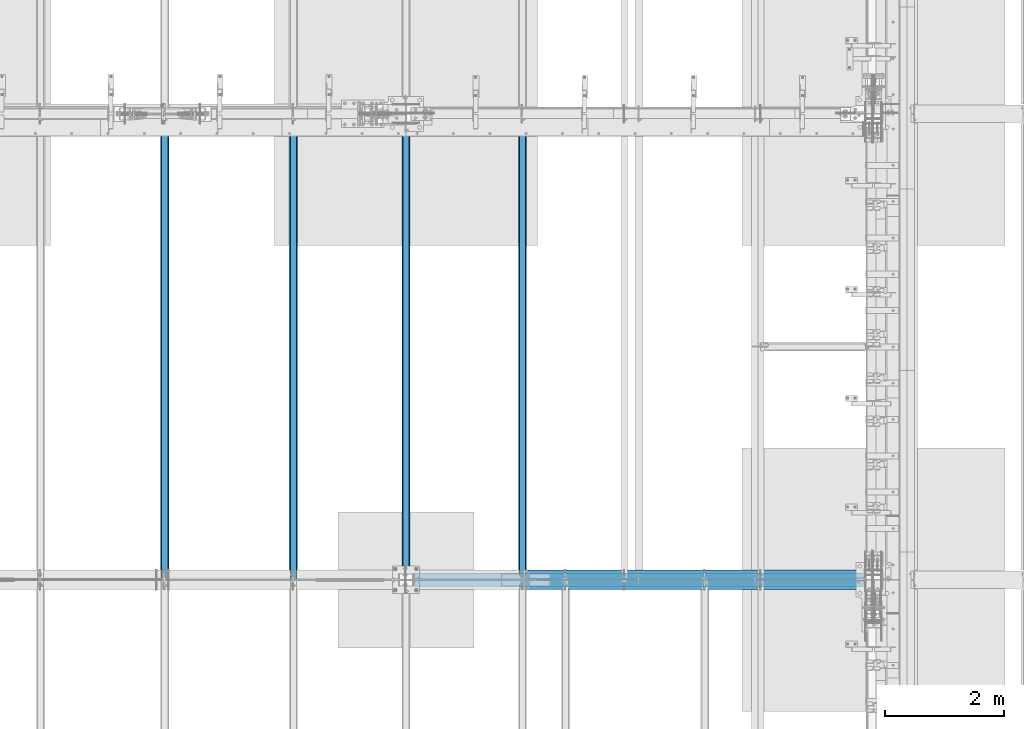
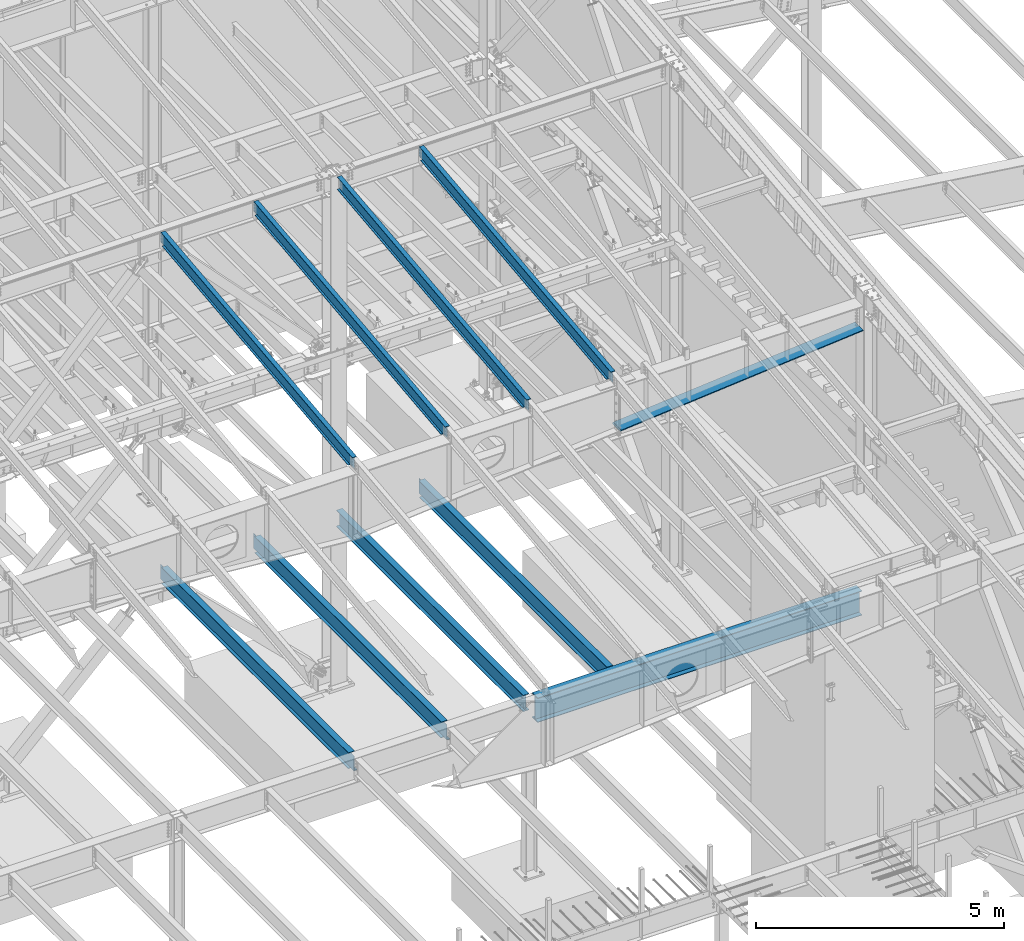
# One storey, part 734 of 1179: 10 beams, 10 elements without a shape of their own.
"""IFC2X3 building model written with IfcOpenShell, lengths in millimetres."""

from ifc_helpers import new_model, si_unit, frame, origin_with_axes, place, context, subcontext, project, spatial, faceted_brep, material, type_object, element, aggregate, save


model = new_model("IFC2X3")

# Units and contexts
model_context = context("Model", 3, precision=1e-05, world=origin_with_axes())
body_context = subcontext(model_context, "Body", "Model", "MODEL_VIEW")
ifc_project = project(units=[si_unit("LENGTHUNIT", "METRE", prefix="MILLI"), si_unit("AREAUNIT", "SQUARE_METRE"), si_unit("VOLUMEUNIT", "CUBIC_METRE"), si_unit("MASSUNIT", "GRAM", prefix="KILO"), si_unit("TIMEUNIT", "SECOND"), si_unit("PLANEANGLEUNIT", "RADIAN"), si_unit("SOLIDANGLEUNIT", "STERADIAN"), si_unit("THERMODYNAMICTEMPERATUREUNIT", "DEGREE_CELSIUS"), si_unit("LUMINOUSINTENSITYUNIT", "LUMEN")], contexts=[model_context])

# Site, building, storey
site_placement = place(None, origin_with_axes())
site = spatial("IfcSite", under=ifc_project, at=site_placement, CompositionType="ELEMENT")
building_placement = place(site_placement, origin_with_axes())
building = spatial("IfcBuilding", under=site, at=building_placement, Name="Undefined", CompositionType="ELEMENT")
storey_placement = place(building_placement, origin_with_axes())
storey = spatial("IfcBuildingStorey", under=building, at=storey_placement, Name="Undefined", CompositionType="ELEMENT", Elevation=0.0)

# Assembly, beam
assembly_1_placement = place(storey_placement, origin_with_axes())
assembly_1 = element("IfcElementAssembly", 1, at=assembly_1_placement, inside=storey, Name="BEAM", AssemblyPlace="NOTDEFINED", PredefinedType="RIGID_FRAME")
ifc_material_1 = material(Name="STEEL/A992")
beam_type_1 = type_object("IfcBeamType", Name="W16X31", PredefinedType="NOTDEFINED")
beam_1_placement = place(assembly_1_placement, frame((14566.9, 19227.8, 3900.4875), z_axis=(0.0, 0.0, 1.0), x_axis=(0.0, 1.0, 0.0)))
beam_1 = element("IfcBeam", 2, at=beam_1_placement, type_object=beam_type_1, material=ifc_material_1, Name="BEAM", ObjectType="W16X31", context=body_context, shape_type="Brep", body=[
    faceted_brep([(113.506251936145, -3.17499999997744, 169.8625), (113.506251936145, 3.17496422017757, 169.8625), (18.2562514952835, 3.17499999999927, 169.8625), (18.2562514952835, -3.17499999999927, 169.8625), (118.366331454192, -3.17499999997926, 170.829229922588), (118.366331454192, 3.17496349569046, 170.829229922588), (122.486507922345, -3.17499999997744, 173.582243823066), (122.486507922345, 3.17496143253265, 173.582243823066), (125.239521822827, -3.17499999997563, 177.70242029122), (125.239521822819, 3.17495834479632, 177.70242029122), (126.206251745411, -3.17499999997744, 182.562499809265), (126.206251745411, 3.1749547025629, 182.562499809265), (126.206251745432, -69.8499999999767, 201.6125), (126.206251745396, 69.850000000024, 201.6125), (126.206251745396, 69.850000000024, 190.5), (126.206251745418, 3.17500000002292, 190.5), (126.206251745411, -3.17499999997744, 190.5), (126.206251745432, -69.8499999999767, 190.5), (7646.9875, 3.17499999999927, -190.5), (7646.9875, 69.8500000000004, -190.5), (145.256250000001, 69.8499999999985, -190.5), (145.256250000001, 3.17549991607666, -190.5), (18.2562500000006, -3.17500000000291, -190.5), (18.2562500000006, -69.8499999999985, -190.5), (7802.5625, -69.8500000000004, -190.5), (7802.5625, -3.17499999999927, -190.5), (18.2562500000006, -69.8499999999985, -201.612499999999), (7802.5625, -69.8500000000004, -201.6125), (7646.9875, 69.8500000000004, -201.6125), (7646.9875, 3.17549991607666, -201.6125), (7802.5625, 3.17549991607666, -201.6125), (18.2562500000006, 3.17549991607666, -201.612499999999), (145.256250000001, 3.17549991607666, -201.612499999999), (145.256250000001, 69.8499999999985, -201.612499999999), (18.2562500000006, 3.17500000000291, -190.5), (7802.5625, 3.17499999999927, -190.5), (7802.5625, 3.17499999999927, 163.512499999999), (7802.5625, -3.17499999999927, 163.512499999999), (7659.68749980926, 3.17499999999927, 163.512499999999), (7659.68749980926, -3.17499999999927, 163.512499999999), (7654.82742029121, 3.17499999999927, 164.479229922587), (7654.82742029121, -3.17499999999927, 164.479229922587), (7650.70724382306, 3.17499999999927, 167.232243823065), (7650.70724382306, -3.17499999999927, 167.232243823065), (7647.95422992258, 3.17499999999927, 171.352420291219), (7647.95422992258, -3.17499999999927, 171.352420291219), (7646.9875, 3.17499999999927, 176.212499809265), (7646.9875, -3.17499999999927, 176.212499809265), (7646.9875, -69.8500000000004, 201.6125), (7646.9875, -69.8500000000004, 190.5), (7646.9875, -3.17499999999927, 190.5), (7646.9875, 3.17499999999927, 190.5), (7646.9875, 69.8500000000004, 190.5), (7646.9875, 69.8500000000004, 201.6125)], [[[0, 1, 2, 3]], [[4, 5, 1, 0]], [[6, 7, 5, 4]], [[8, 9, 7, 6]], [[10, 11, 9, 8]], [[12, 13, 14, 15, 11, 10, 16, 17]], [[18, 19, 20, 21]], [[22, 23, 24, 25]], [[23, 26, 27, 24]], [[28, 29, 30, 27, 26, 31, 32, 33]], [[21, 32, 31, 34]], [[20, 33, 32, 21]], [[19, 28, 33, 20]], [[18, 29, 28, 19]], [[35, 30, 29, 18]], [[25, 24, 27, 30, 35, 36, 37]], [[37, 36, 38, 39]], [[39, 38, 40, 41]], [[41, 40, 42, 43]], [[43, 42, 44, 45]], [[45, 44, 46, 47]], [[48, 49, 50, 47, 46, 51, 52, 53]], [[49, 48, 12, 17]], [[50, 49, 17, 16]], [[8, 6, 4, 0, 3, 22, 25, 37, 39, 41, 43, 45, 47, 50, 16, 10]], [[34, 31, 26, 23, 22, 3, 2]], [[51, 46, 44, 42, 40, 38, 36, 35, 18, 21, 34, 2, 1, 5, 7, 9, 11, 15]], [[52, 51, 15, 14]], [[53, 52, 14, 13]], [[48, 53, 13, 12]]]),
])
aggregate(assembly_1, [beam_1])

assembly_2_placement = place(storey_placement, origin_with_axes())
assembly_2 = element("IfcElementAssembly", 3, at=assembly_2_placement, inside=storey, Name="BEAM", AssemblyPlace="NOTDEFINED", PredefinedType="RIGID_FRAME")
beam_2_placement = place(assembly_2_placement, frame((12407.9, 19227.8, 3900.4875), z_axis=(0.0, 0.0, 1.0), x_axis=(0.0, 1.0, 0.0)))
beam_2 = element("IfcBeam", 4, at=beam_2_placement, type_object=beam_type_1, material=ifc_material_1, Name="BEAM", ObjectType="W16X31", context=body_context, shape_type="Brep", body=[
    faceted_brep([(113.506251936145, -3.17499999997744, 169.8625), (113.506251936145, 3.17496422017757, 169.8625), (18.2562514952835, 3.17499999999927, 169.8625), (18.2562514952835, -3.17499999999927, 169.8625), (118.366331454192, -3.17499999997926, 170.829229922588), (118.366331454192, 3.17496349569046, 170.829229922588), (122.486507922345, -3.17499999997744, 173.582243823066), (122.486507922345, 3.17496143253265, 173.582243823066), (125.239521822827, -3.17499999997563, 177.70242029122), (125.239521822819, 3.17495834479632, 177.70242029122), (126.206251745411, -3.17499999997744, 182.562499809265), (126.206251745411, 3.1749547025629, 182.562499809265), (126.206251745432, -69.8499999999767, 201.6125), (126.206251745396, 69.850000000024, 201.6125), (126.206251745396, 69.850000000024, 190.5), (126.206251745418, 3.17500000002292, 190.5), (126.206251745411, -3.17499999997744, 190.5), (126.206251745432, -69.8499999999767, 190.5), (7646.9875, 3.17499999999927, -190.5), (7646.9875, 69.8500000000004, -190.5), (145.256250000001, 69.8499999999985, -190.5), (145.256250000001, 3.17549991607666, -190.5), (18.2562500000006, -3.17500000000291, -190.5), (18.2562500000006, -69.8499999999985, -190.5), (7802.5625, -69.8500000000004, -190.5), (7802.5625, -3.17499999999927, -190.5), (18.2562500000006, -69.8499999999985, -201.612499999999), (7802.5625, -69.8500000000004, -201.6125), (7646.9875, 69.8500000000004, -201.6125), (7646.9875, 3.17537004679616, -201.6125), (7802.5625, 3.17537004679616, -201.6125), (18.2562500000006, 3.17549991607666, -201.612499999999), (145.256250000001, 3.17549991607666, -201.612499999999), (145.256250000001, 69.8499999999985, -201.612499999999), (18.2562500000006, 3.17500000000291, -190.5), (7802.5625, 3.17499999999927, -190.5), (7802.5625, 3.17499999999927, 163.512499999999), (7802.5625, -3.17499999999927, 163.512499999999), (7659.68749980926, 3.17499999999927, 163.512499999999), (7659.68749980926, -3.17499999999927, 163.512499999999), (7654.82742029121, 3.17499999999927, 164.479229922587), (7654.82742029121, -3.17499999999927, 164.479229922587), (7650.70724382306, 3.17499999999927, 167.232243823065), (7650.70724382306, -3.17499999999927, 167.232243823065), (7647.95422992258, 3.17499999999927, 171.352420291219), (7647.95422992258, -3.17499999999927, 171.352420291219), (7646.9875, 3.17499999999927, 176.212499809265), (7646.9875, -3.17499999999927, 176.212499809265), (7646.9875, -69.8500000000004, 201.6125), (7646.9875, -69.8500000000004, 190.5), (7646.9875, -3.17499999999927, 190.5), (7646.9875, 3.17499999999927, 190.5), (7646.9875, 69.8500000000004, 190.5), (7646.9875, 69.8500000000004, 201.6125)], [[[0, 1, 2, 3]], [[4, 5, 1, 0]], [[6, 7, 5, 4]], [[8, 9, 7, 6]], [[10, 11, 9, 8]], [[12, 13, 14, 15, 11, 10, 16, 17]], [[18, 19, 20, 21]], [[22, 23, 24, 25]], [[23, 26, 27, 24]], [[28, 29, 30, 27, 26, 31, 32, 33]], [[21, 32, 31, 34]], [[20, 33, 32, 21]], [[19, 28, 33, 20]], [[18, 29, 28, 19]], [[35, 30, 29, 18]], [[25, 24, 27, 30, 35, 36, 37]], [[37, 36, 38, 39]], [[39, 38, 40, 41]], [[41, 40, 42, 43]], [[43, 42, 44, 45]], [[45, 44, 46, 47]], [[48, 49, 50, 47, 46, 51, 52, 53]], [[49, 48, 12, 17]], [[50, 49, 17, 16]], [[8, 6, 4, 0, 3, 22, 25, 37, 39, 41, 43, 45, 47, 50, 16, 10]], [[34, 31, 26, 23, 22, 3, 2]], [[51, 46, 44, 42, 40, 38, 36, 35, 18, 21, 34, 2, 1, 5, 7, 9, 11, 15]], [[52, 51, 15, 14]], [[53, 52, 14, 13]], [[48, 53, 13, 12]]]),
])
aggregate(assembly_2, [beam_2])

assembly_3_placement = place(storey_placement, origin_with_axes())
assembly_3 = element("IfcElementAssembly", 5, at=assembly_3_placement, inside=storey, Name="BEAM", AssemblyPlace="NOTDEFINED", PredefinedType="RIGID_FRAME")
beam_3_placement = place(assembly_3_placement, frame((16459.2, 19227.8, 3900.4875), z_axis=(0.0, 0.0, 1.0), x_axis=(0.0, 1.0, 0.0)))
beam_3 = element("IfcBeam", 6, at=beam_3_placement, type_object=beam_type_1, material=ifc_material_1, Name="BEAM", ObjectType="W16X31", context=body_context, shape_type="Brep", body=[
    faceted_brep([(114.299999999999, -69.8500000000004, -201.6125), (114.299999999999, 69.8500000000004, -201.6125), (7627.9375, 69.8500000000004, -201.6125), (7627.9375, -69.8500000000004, -201.6125), (114.299999999999, -69.8500000000004, -190.5), (114.299999999999, -3.17499999999927, -190.5), (114.299999999999, -3.17499999999927, 190.5), (114.299999999999, -69.8500000000004, 190.5), (114.299999999999, -69.8500000000004, 201.6125), (114.299999999999, 69.8500000000004, 201.6125), (114.299999999999, 69.8500000000004, 190.5), (114.299999999999, 3.17499999999927, 190.5), (114.299999999999, 3.17499999999927, 164.25250072541), (114.299999999999, 3.17499999999927, -142.0275032968), (114.299999999999, 3.17499999999927, -190.5), (114.299999999999, 69.8500000000004, -190.5), (7627.9375, -69.8500000000004, -190.5), (7627.9375, -3.17499999999927, -190.5), (7627.9375, -3.17499999999927, 190.5), (7627.9375, -69.8500000000004, 190.5), (7627.9375, -69.8500000000004, 201.6125), (7627.9375, 69.8500000000004, 201.6125), (7627.9375, 69.8500000000004, 190.5), (7627.9375, 3.17499999999927, 190.5), (7627.9375, 3.17499999999927, -190.5), (7627.9375, 69.8500000000004, -190.5)], [[[0, 1, 2, 3]], [[0, 4, 5, 6, 7, 8, 9, 10, 11, 12, 13, 14, 15, 1]], [[5, 4, 16, 17]], [[6, 5, 17, 18]], [[7, 6, 18, 19]], [[8, 7, 19, 20]], [[9, 8, 20, 21]], [[10, 9, 21, 22]], [[11, 10, 22, 23]], [[14, 13, 12, 11, 23, 24]], [[15, 14, 24, 25]], [[1, 15, 25, 2]], [[24, 23, 22, 21, 20, 19, 18, 17, 16, 3, 2, 25]], [[4, 0, 3, 16]]]),
])
aggregate(assembly_3, [beam_3])

assembly_4_placement = place(storey_placement, origin_with_axes())
assembly_4 = element("IfcElementAssembly", 7, at=assembly_4_placement, inside=storey, Name="BEAM", AssemblyPlace="NOTDEFINED", PredefinedType="RIGID_FRAME")
beam_4_placement = place(assembly_4_placement, frame((18415.0, 19227.8, 3900.4875), z_axis=(0.0, 0.0, 1.0), x_axis=(0.0, 1.0, 0.0)))
beam_4 = element("IfcBeam", 8, at=beam_4_placement, type_object=beam_type_1, material=ifc_material_1, Name="BEAM", ObjectType="W16X31", context=body_context, shape_type="Brep", body=[
    faceted_brep([(113.506251936145, -3.17499999997744, 169.8625), (113.506251936145, 3.17496422017757, 169.8625), (18.2562514952835, 3.17499999999927, 169.8625), (18.2562514952835, -3.17499999999927, 169.8625), (118.366331454192, -3.17499999997926, 170.829229922588), (118.366331454192, 3.17496349569046, 170.829229922588), (122.486507922345, -3.17499999997744, 173.582243823066), (122.486507922345, 3.17496143253265, 173.582243823066), (125.239521822827, -3.17499999997563, 177.70242029122), (125.239521822819, 3.17495834479632, 177.70242029122), (126.206251745411, -3.17499999997744, 182.562499809265), (126.206251745411, 3.1749547025629, 182.562499809265), (126.206251745432, -69.8499999999767, 201.6125), (126.206251745396, 69.850000000024, 201.6125), (126.206251745396, 69.850000000024, 190.5), (126.206251745418, 3.17500000002292, 190.5), (126.206251745411, -3.17499999997744, 190.5), (126.206251745432, -69.8499999999767, 190.5), (7677.15000000001, 3.17499999999927, -190.5), (7677.15000000001, 69.8499999999985, -190.5), (145.256250000001, 69.8499999999985, -190.5), (145.256250000001, 3.17549991607666, -190.5), (18.2562500000006, -3.17500000000291, -190.5), (18.2562500000006, -69.8499999999985, -190.5), (7804.15, -69.8499999999985, -190.5), (7804.15, -3.17499999999927, -190.5), (18.2562500000006, -69.8499999999985, -201.612499999999), (7804.15, -69.8499999999985, -201.6125), (7677.15000000001, 69.8499999999985, -201.6125), (7677.15000000001, 3.17549991607666, -201.6125), (7804.15, 3.17549991607666, -201.6125), (18.2562500000006, 3.17549991607666, -201.612499999999), (145.256250000001, 3.17549991607666, -201.612499999999), (145.256250000001, 69.8499999999985, -201.612499999999), (18.2562500000006, 3.17500000000291, -190.5), (7804.15, 3.17499999999927, -190.5), (7804.15, 3.17499999999927, 169.8625), (7804.15, -3.17499999999927, 169.8625), (7708.89999980925, 3.17499999999927, 169.8625), (7708.89999980925, -3.17499999999927, 169.8625), (7704.03992029121, 3.17499999999927, 170.829229922588), (7704.03992029121, -3.17499999999927, 170.829229922588), (7699.91974382305, 3.17499999999927, 173.582243823066), (7699.91974382305, -3.17499999999927, 173.582243823066), (7697.16672992258, 3.17499999999927, 177.70242029122), (7697.16672992258, -3.17499999999927, 177.70242029122), (7696.19999999999, 3.17499999999927, 182.562499809265), (7696.19999999999, -3.17499999999927, 182.562499809265), (7696.19999999999, -69.8499999999985, 201.6125), (7696.19999999999, -69.8499999999985, 190.5), (7696.19999999999, -3.17499999999927, 190.5), (7696.19999999999, 3.17499999999927, 190.5), (7696.19999999999, 69.8499999999985, 190.5), (7696.19999999999, 69.8499999999985, 201.6125)], [[[0, 1, 2, 3]], [[4, 5, 1, 0]], [[6, 7, 5, 4]], [[8, 9, 7, 6]], [[10, 11, 9, 8]], [[12, 13, 14, 15, 11, 10, 16, 17]], [[18, 19, 20, 21]], [[22, 23, 24, 25]], [[23, 26, 27, 24]], [[28, 29, 30, 27, 26, 31, 32, 33]], [[21, 32, 31, 34]], [[20, 33, 32, 21]], [[19, 28, 33, 20]], [[18, 29, 28, 19]], [[35, 30, 29, 18]], [[25, 24, 27, 30, 35, 36, 37]], [[37, 36, 38, 39]], [[39, 38, 40, 41]], [[41, 40, 42, 43]], [[43, 42, 44, 45]], [[45, 44, 46, 47]], [[48, 49, 50, 47, 46, 51, 52, 53]], [[49, 48, 12, 17]], [[50, 49, 17, 16]], [[8, 6, 4, 0, 3, 22, 25, 37, 39, 41, 43, 45, 47, 50, 16, 10]], [[34, 31, 26, 23, 22, 3, 2]], [[51, 46, 44, 42, 40, 38, 36, 35, 18, 21, 34, 2, 1, 5, 7, 9, 11, 15]], [[52, 51, 15, 14]], [[53, 52, 14, 13]], [[48, 53, 13, 12]]]),
])
aggregate(assembly_4, [beam_4])

assembly_5_placement = place(storey_placement, origin_with_axes())
assembly_5 = element("IfcElementAssembly", 9, at=assembly_5_placement, inside=storey, Name="RAFTER BEAM", AssemblyPlace="NOTDEFINED", PredefinedType="RIGID_FRAME")
ifc_material_2 = material(Name="STEEL/A36")
beam_type_2 = type_object("IfcBeamType", PredefinedType="NOTDEFINED")
beam_5_placement = place(assembly_5_placement, frame((18466.7699127408, 19227.800000002, 10032.2486581317), z_axis=(0.0, 1.0, 0.0), x_axis=(0.996183710890709, 0.0, 0.0872812359904244)))
beam_5 = element("IfcBeam", 10, at=beam_5_placement, type_object=beam_type_2, material=ifc_material_2, Name="PLATE", context=body_context, shape_type="Brep", body=[
    faceted_brep([(50.043578213099, -11.1125244904742, 165.1), (23.5500482208263, 11.1125000000075, 165.1), (23.5500482208263, 11.1125000000075, -165.1), (50.0435782131026, -11.1125000000075, -165.1), (5693.8669426845, -11.1124999999474, 165.1), (5693.8669426845, -11.1124999999474, -165.1), (5691.91968591988, 11.1125000000657, -165.1), (5691.91968591988, 11.1125000000657, 165.1)], [[[0, 1, 2, 3]], [[4, 5, 6, 7]], [[5, 4, 0, 3]], [[6, 5, 3, 2]], [[7, 6, 2, 1]], [[4, 7, 1, 0]]]),
])
aggregate(assembly_5, [beam_5])

assembly_6_placement = place(storey_placement, origin_with_axes())
assembly_6 = element("IfcElementAssembly", 11, at=assembly_6_placement, inside=storey, Name="BEAM", AssemblyPlace="NOTDEFINED", PredefinedType="RIGID_FRAME")
beam_type_3 = type_object("IfcBeamType", Name="W12X22", PredefinedType="NOTDEFINED")
beam_6_placement = place(assembly_6_placement, frame((18415.0, 19245.2779321397, 11265.0059190149), z_axis=(0.0, -0.112284087038017, 0.993676146336441), x_axis=(0.0, 0.993676146336441, 0.112284087038017)))
beam_6 = element("IfcBeam", 12, at=beam_6_placement, type_object=beam_type_3, material=ifc_material_1, Name="BEAM", ObjectType="W12X22", context=body_context, shape_type="Brep", body=[
    faceted_brep([(7676.8057846648, 3.17499999999927, -144.462500003032), (7676.80578466482, 3.17490308365814, -155.575000003026), (7676.80577856895, 50.7999999999993, -155.575000003026), (7676.80577856896, 50.7999999999993, -144.462500003034), (7820.7019525921, 3.17499999999927, -144.462500003092), (7819.44625482597, 3.17492134140048, -155.575000003084), (5.12531926095107, 3.17499999999927, 144.46249999992), (5.12531926095107, 50.7999999999993, 144.46249999992), (7757.4939140051, 50.7999999999993, 144.462499996773), (7757.4939140051, 3.17499999999927, 144.462499996773), (5.12531926095107, -3.17499999999927, 144.46249999992), (5.12531926095107, -50.7999999999993, 144.46249999992), (6.38101702707718, -50.7999999999993, 155.574999999912), (6.38101702707718, 50.7999999999993, 155.574999999912), (-23.6361487119248, 3.17499999999927, -110.066751837681), (-23.6361487119248, -3.17499999999927, -110.066751837681), (140.429059546248, 3.17499999999927, -128.605903005757), (140.429059546248, -3.17499999999927, -128.605903005757), (145.149856241293, 3.17499999999927, -130.112229064427), (145.149856241293, -3.17499999999927, -130.112229064427), (148.934857659475, 3.17499999999927, -133.310463561033), (148.934857659475, -3.17499999999927, -133.310463561033), (151.207831646803, 3.17499999999927, -137.713704286212), (151.207831646803, -3.17499999999927, -137.713704286212), (151.622738518741, 3.17499999999927, -142.651597755959), (151.622738518741, -3.17499999999927, -142.651597755959), (151.418108966391, -3.17499999999927, -144.46249999998), (151.418108966391, -50.7999999999993, -144.46249999998), (7676.805791578, -50.7999999999993, -144.462500003034), (7676.805785482, -3.17499999999927, -144.462500003032), (151.418108966391, 3.17499999999927, -144.46249999998), (151.418108966391, 50.7999999999993, -144.46249999998), (150.1624112014, 50.7999999999993, -155.574999999972), (150.1624112014, -50.7999999999993, -155.574999999972), (7676.805791578, -50.7999999999993, -155.575000003026), (7676.80578548203, -3.17509692720705, -155.575000003026), (7820.7019525921, -3.17499999999927, -144.462500003092), (7819.44625482597, -3.17507866903179, -155.575000003084), (7760.28182167741, -3.17499999999927, 99.3123538561285), (7756.49682025474, -3.17499999999927, 102.510588352729), (7754.22384626446, -3.17499999999927, 106.91382908024), (7753.80893939206, -3.17499999999927, 111.851722553385), (7757.4939140051, -3.17499999999927, 144.462499996773), (7821.50556176969, -3.17499999999927, -137.350830916108), (7847.03058449439, -3.17499999999927, 88.5369763886902), (7765.00261837702, -3.17499999999927, 97.8060278004923), (7757.4939140051, -50.7999999999993, 144.462499996773), (7758.74961177122, -50.7999999999993, 155.574999996767), (7758.74961177122, 50.7999999999993, 155.574999996767), (7753.80893939206, 3.17499999999927, 111.851722553385), (7754.22384626446, 3.17499999999927, 106.91382908024), (7756.49682025474, 3.17499999999927, 102.510588352729), (7760.28182167741, 3.17499999999927, 99.3123538561285), (7765.00261837702, 3.17499999999927, 97.8060278004923), (7847.03058449439, 3.17499999999927, 88.5369763886902), (7821.50554925474, 3.17499999999927, -137.350941669098)], [[[0, 1, 2, 3]], [[4, 5, 1, 0]], [[6, 7, 8, 9]], [[10, 11, 12, 13, 7, 6, 14, 15]], [[15, 14, 16, 17]], [[17, 16, 18, 19]], [[19, 18, 20, 21]], [[21, 20, 22, 23]], [[23, 22, 24, 25]], [[26, 27, 28, 29]], [[25, 24, 30, 31, 32, 33, 27, 26]], [[27, 33, 34, 28]], [[28, 34, 35, 29]], [[36, 29, 35, 37]], [[38, 39, 40, 41, 42, 10, 15, 17, 19, 21, 23, 25, 26, 29, 36, 43, 44, 45]], [[11, 10, 42, 46]], [[12, 11, 46, 47]], [[13, 12, 47, 48]], [[7, 13, 48, 8]], [[47, 46, 42, 41, 49, 9, 8, 48]], [[40, 50, 49, 41]], [[39, 51, 50, 40]], [[38, 52, 51, 39]], [[45, 53, 52, 38]], [[44, 54, 53, 45]], [[55, 4, 0, 30, 24, 22, 20, 18, 16, 14, 6, 9, 49, 50, 51, 52, 53, 54]], [[31, 30, 0, 3]], [[32, 31, 3, 2]], [[37, 35, 34, 33, 32, 2, 1, 5]], [[55, 54, 44, 43, 36, 37, 5, 4]]]),
])
aggregate(assembly_6, [beam_6])

assembly_7_placement = place(storey_placement, origin_with_axes())
assembly_7 = element("IfcElementAssembly", 13, at=assembly_7_placement, inside=storey, Name="BEAM", AssemblyPlace="NOTDEFINED", PredefinedType="RIGID_FRAME")
beam_7_placement = place(assembly_7_placement, frame((16459.2, 19245.2779321397, 11265.0059190149), z_axis=(0.0, -0.112284087038017, 0.993676146336441), x_axis=(0.0, 0.993676146336441, 0.112284087038017)))
beam_7 = element("IfcBeam", 14, at=beam_7_placement, type_object=beam_type_3, material=ifc_material_1, Name="BEAM", ObjectType="W12X22", context=body_context, shape_type="Brep", body=[
    faceted_brep([(6.38101702707718, -50.7999999999993, 155.574999999912), (5.12531926095107, -50.7999999999993, 144.46249999992), (7675.21735919066, -50.7999999999993, 144.462499996805), (7676.47305695679, -50.7999999999993, 155.574999996801), (6.38101702707718, 50.7999999999993, 155.574999999912), (7676.47305695679, 50.7999999999993, 155.574999996801), (5.12531926095107, 50.7999999999993, 144.46249999992), (7675.21735919066, 50.7999999999993, 144.462499996805), (5.12531926095107, 3.17499999999927, 144.46249999992), (7675.21735919066, 3.17499999999927, 144.462499996805), (5.12531926095107, -3.17499999999927, 144.46249999992), (-25.0621566261689, 3.17499999999927, -122.686438896275), (-25.0621566261689, -3.17499999999927, -122.686438896275), (7675.21735919066, -3.17499999999927, 144.462499996805), (7642.56921727134, 3.17499999999927, -144.462500003019), (7642.56921727134, -3.17499999999927, -144.462500003019), (7642.56921727134, -50.7999999999993, -144.462500003019), (7641.31351950521, -50.7999999999993, -155.575000003011), (7641.31351950521, 50.7999999999993, -155.575000003011), (7642.56921727134, 50.7999999999993, -144.462500003019), (145.027696926005, -50.7999999999993, -144.462499999976), (143.771999161854, -50.7999999999993, -155.574999999972), (143.771999161854, 50.7999999999993, -155.574999999972), (145.027696926005, 50.7999999999993, -144.462499999976), (145.027696926005, 3.17499999999927, -144.462499999976), (145.312894957096, 3.17499999999927, -141.93859400049), (145.312894957096, -3.17499999999927, -141.93859400049), (145.027696926005, -3.17499999999927, -144.462499999976)], [[[0, 1, 2, 3]], [[4, 0, 3, 5]], [[6, 4, 5, 7]], [[8, 6, 7, 9]], [[10, 1, 0, 4, 6, 8, 11, 12]], [[1, 10, 13, 2]], [[14, 9, 7, 5, 3, 2, 13, 15, 16, 17, 18, 19]], [[17, 16, 20, 21]], [[18, 17, 21, 22]], [[19, 18, 22, 23]], [[14, 19, 23, 24]], [[8, 9, 14, 24, 25, 11]], [[12, 11, 25, 26]], [[15, 13, 10, 12, 26, 27]], [[16, 15, 27, 20]], [[26, 25, 24, 23, 22, 21, 20, 27]]]),
])
aggregate(assembly_7, [beam_7])

assembly_8_placement = place(storey_placement, origin_with_axes())
assembly_8 = element("IfcElementAssembly", 15, at=assembly_8_placement, inside=storey, Name="BEAM", AssemblyPlace="NOTDEFINED", PredefinedType="RIGID_FRAME")
beam_8_placement = place(assembly_8_placement, frame((14566.9, 19245.2779321397, 11265.0059190149), z_axis=(0.0, -0.112284087038017, 0.993676146336441), x_axis=(0.0, 0.993676146336441, 0.112284087038017)))
beam_8 = element("IfcBeam", 16, at=beam_8_placement, type_object=beam_type_3, material=ifc_material_1, Name="BEAM", ObjectType="W12X22", context=body_context, shape_type="Brep", body=[
    faceted_brep([(7676.8057846648, 3.17499999999927, -144.462500003032), (7676.80578466482, 3.17490308365814, -155.575000003026), (7676.80577856895, 50.7999999999993, -155.575000003026), (7676.80577856896, 50.7999999999993, -144.462500003034), (7820.7019525921, 3.17499999999927, -144.462500003092), (7819.44625482597, 3.17492134140048, -155.575000003084), (5.12531926095107, 3.17499999999927, 144.46249999992), (5.12531926095107, 50.7999999999993, 144.46249999992), (7757.4939140051, 50.7999999999993, 144.462499996773), (7757.4939140051, 3.17499999999927, 144.462499996773), (5.12531926095107, -3.17499999999927, 144.46249999992), (5.12531926095107, -50.7999999999993, 144.46249999992), (6.38101702707718, -50.7999999999993, 155.574999999912), (6.38101702707718, 50.7999999999993, 155.574999999912), (-25.0621566261689, 3.17499999999927, -122.686438896275), (-25.0621566261689, -3.17499999999927, -122.686438896275), (145.312894957096, 3.17499999999927, -141.93859400049), (145.312894957096, -3.17499999999927, -141.93859400049), (145.027696926005, -3.17499999999927, -144.462499999976), (145.027696926005, -50.7999999999993, -144.462499999976), (7676.805791578, -50.7999999999993, -144.462500003034), (7676.805785482, -3.17499999999927, -144.462500003032), (145.027696926005, 3.17499999999927, -144.462499999976), (145.027696926005, 50.7999999999993, -144.462499999976), (143.771999161854, 50.7999999999993, -155.574999999972), (143.771999161854, -50.7999999999993, -155.574999999972), (7676.805791578, -50.7999999999993, -155.575000003026), (7676.80578548203, -3.17509692720705, -155.575000003026), (7820.7019525921, -3.17499999999927, -144.462500003092), (7819.44625482597, -3.17507866903179, -155.575000003084), (7760.28182167741, -3.17499999999927, 99.3123538561285), (7756.49682025474, -3.17499999999927, 102.510588352729), (7754.22384626446, -3.17499999999927, 106.91382908024), (7753.80893939206, -3.17499999999927, 111.851722553385), (7757.4939140051, -3.17499999999927, 144.462499996773), (7821.50556176969, -3.17499999999927, -137.350830916108), (7847.03058449439, -3.17499999999927, 88.5369763886902), (7765.00261837702, -3.17499999999927, 97.8060278004923), (7757.4939140051, -50.7999999999993, 144.462499996773), (7758.74961177122, -50.7999999999993, 155.574999996767), (7758.74961177122, 50.7999999999993, 155.574999996767), (7753.80893939206, 3.17499999999927, 111.851722553385), (7754.22384626446, 3.17499999999927, 106.91382908024), (7756.49682025474, 3.17499999999927, 102.510588352729), (7760.28182167741, 3.17499999999927, 99.3123538561285), (7765.00261837702, 3.17499999999927, 97.8060278004923), (7847.03058449439, 3.17499999999927, 88.5369763886902), (7821.50554925474, 3.17499999999927, -137.350941669098)], [[[0, 1, 2, 3]], [[4, 5, 1, 0]], [[6, 7, 8, 9]], [[10, 11, 12, 13, 7, 6, 14, 15]], [[15, 14, 16, 17]], [[18, 19, 20, 21]], [[17, 16, 22, 23, 24, 25, 19, 18]], [[19, 25, 26, 20]], [[20, 26, 27, 21]], [[28, 21, 27, 29]], [[30, 31, 32, 33, 34, 10, 15, 17, 18, 21, 28, 35, 36, 37]], [[11, 10, 34, 38]], [[12, 11, 38, 39]], [[13, 12, 39, 40]], [[7, 13, 40, 8]], [[39, 38, 34, 33, 41, 9, 8, 40]], [[32, 42, 41, 33]], [[31, 43, 42, 32]], [[30, 44, 43, 31]], [[37, 45, 44, 30]], [[36, 46, 45, 37]], [[47, 4, 0, 22, 16, 14, 6, 9, 41, 42, 43, 44, 45, 46]], [[23, 22, 0, 3]], [[24, 23, 3, 2]], [[29, 27, 26, 25, 24, 2, 1, 5]], [[47, 46, 36, 35, 28, 29, 5, 4]]]),
])
aggregate(assembly_8, [beam_8])

assembly_9_placement = place(storey_placement, origin_with_axes())
assembly_9 = element("IfcElementAssembly", 17, at=assembly_9_placement, inside=storey, Name="BEAM", AssemblyPlace="NOTDEFINED", PredefinedType="RIGID_FRAME")
beam_9_placement = place(assembly_9_placement, frame((12407.9, 19245.2779321397, 11265.0059190149), z_axis=(0.0, -0.112284087038017, 0.993676146336441), x_axis=(0.0, 0.993676146336441, 0.112284087038017)))
beam_9 = element("IfcBeam", 18, at=beam_9_placement, type_object=beam_type_3, material=ifc_material_1, Name="BEAM", ObjectType="W12X22", context=body_context, shape_type="Brep", body=[
    faceted_brep([(7676.8057846648, 3.17499999999927, -144.462500003032), (7676.80578466482, 3.17490308365814, -155.575000003026), (7676.80577856895, 50.7999999999993, -155.575000003026), (7676.80577856896, 50.7999999999993, -144.462500003034), (7820.7019525921, 3.17499999999927, -144.462500003092), (7819.44625482597, 3.17492134140048, -155.575000003084), (5.12531926095107, 3.17499999999927, 144.46249999992), (5.12531926095107, 50.7999999999993, 144.46249999992), (7757.4939140051, 50.7999999999993, 144.462499996773), (7757.4939140051, 3.17499999999927, 144.462499996773), (5.12531926095107, -3.17499999999927, 144.46249999992), (5.12531926095107, -50.7999999999993, 144.46249999992), (6.38101702707718, -50.7999999999993, 155.574999999912), (6.38101702707718, 50.7999999999993, 155.574999999912), (-25.0621566261689, 3.17499999999927, -122.686438896275), (-25.0621566261689, -3.17499999999927, -122.686438896275), (145.312894957096, 3.17499999999927, -141.93859400049), (145.312894957096, -3.17499999999927, -141.93859400049), (145.027696926005, -3.17499999999927, -144.462499999976), (145.027696926005, -50.7999999999993, -144.462499999976), (7676.805791578, -50.7999999999993, -144.462500003034), (7676.805785482, -3.17499999999927, -144.462500003032), (145.027696926005, 3.17499999999927, -144.462499999976), (145.027696926005, 50.7999999999993, -144.462499999976), (143.771999161854, 50.7999999999993, -155.574999999972), (143.771999161854, -50.7999999999993, -155.574999999972), (7676.805791578, -50.7999999999993, -155.575000003026), (7676.80578548203, -3.17509692720705, -155.575000003026), (7820.7019525921, -3.17499999999927, -144.462500003092), (7819.44625482597, -3.17507866903179, -155.575000003084), (7760.28182167741, -3.17499999999927, 99.3123538561285), (7756.49682025474, -3.17499999999927, 102.510588352729), (7754.22384626446, -3.17499999999927, 106.91382908024), (7753.80893939206, -3.17499999999927, 111.851722553385), (7757.4939140051, -3.17499999999927, 144.462499996773), (7821.50556176969, -3.17499999999927, -137.350830916108), (7847.03058449439, -3.17499999999927, 88.5369763886902), (7765.00261837702, -3.17499999999927, 97.8060278004923), (7757.4939140051, -50.7999999999993, 144.462499996773), (7758.74961177122, -50.7999999999993, 155.574999996767), (7758.74961177122, 50.7999999999993, 155.574999996767), (7753.80893939206, 3.17499999999927, 111.851722553385), (7754.22384626446, 3.17499999999927, 106.91382908024), (7756.49682025474, 3.17499999999927, 102.510588352729), (7760.28182167741, 3.17499999999927, 99.3123538561285), (7765.00261837702, 3.17499999999927, 97.8060278004923), (7847.03058449439, 3.17499999999927, 88.5369763886902), (7821.50554925474, 3.17499999999927, -137.350941669098)], [[[0, 1, 2, 3]], [[4, 5, 1, 0]], [[6, 7, 8, 9]], [[10, 11, 12, 13, 7, 6, 14, 15]], [[15, 14, 16, 17]], [[18, 19, 20, 21]], [[17, 16, 22, 23, 24, 25, 19, 18]], [[19, 25, 26, 20]], [[20, 26, 27, 21]], [[28, 21, 27, 29]], [[30, 31, 32, 33, 34, 10, 15, 17, 18, 21, 28, 35, 36, 37]], [[11, 10, 34, 38]], [[12, 11, 38, 39]], [[13, 12, 39, 40]], [[7, 13, 40, 8]], [[39, 38, 34, 33, 41, 9, 8, 40]], [[32, 42, 41, 33]], [[31, 43, 42, 32]], [[30, 44, 43, 31]], [[37, 45, 44, 30]], [[36, 46, 45, 37]], [[47, 4, 0, 22, 16, 14, 6, 9, 41, 42, 43, 44, 45, 46]], [[23, 22, 0, 3]], [[24, 23, 3, 2]], [[29, 27, 26, 25, 24, 2, 1, 5]], [[47, 46, 36, 35, 28, 29, 5, 4]]]),
])
aggregate(assembly_9, [beam_9])

assembly_10_placement = place(storey_placement, origin_with_axes())
assembly_10 = element("IfcElementAssembly", 19, at=assembly_10_placement, inside=storey, Name="BEAM", AssemblyPlace="NOTDEFINED", PredefinedType="RIGID_FRAME")
beam_type_4 = type_object("IfcBeamType", Name="W24X68", PredefinedType="NOTDEFINED")
beam_10_placement = place(assembly_10_placement, frame((16459.2, 19227.8, 3800.475), z_axis=(0.0, 0.0, 1.0), x_axis=(1.0, 0.0, 0.0)))
beam_10 = element("IfcBeam", 20, at=beam_10_placement, type_object=beam_type_4, material=ifc_material_1, Name="BEAM", ObjectType="W24X68", context=body_context, shape_type="Brep", body=[
    faceted_brep([(138.112499999999, -114.299999999999, -301.625), (138.112499999999, 114.299999999999, -301.625), (7678.7375, 114.299999999999, -301.625), (7678.7375, -114.299999999999, -301.625), (138.112499999999, -114.299999999999, -287.3375), (138.112499999999, -5.55625000000146, -287.3375), (138.112499999999, -5.55625000000146, 287.3375), (138.112499999999, -114.299999999999, 287.3375), (138.112499999999, -114.299999999999, 301.625), (138.112499999999, 114.299999999999, 301.625), (138.112499999999, 114.299999999999, 287.3375), (138.112499999999, 5.55625000000146, 287.3375), (138.112499999999, 5.55625000000146, -287.3375), (138.112499999999, 114.299999999999, -287.3375), (7678.73749918356, -114.299999999999, -287.3375), (7678.7375, -5.55625000000146, -287.3375), (7678.7375, -5.55625000000146, 287.3375), (7678.73749918356, -114.299999999999, 287.3375), (7678.7375, -114.299999999999, 301.625), (7678.7375, 114.299999999999, 301.625), (7678.73749918356, 114.299999999999, 287.3375), (7678.7375, 5.55625000000146, 287.3375), (7678.7375, 5.55625000000146, -287.3375), (7678.73749918356, 114.299999999999, -287.3375)], [[[0, 1, 2, 3]], [[0, 4, 5, 6, 7, 8, 9, 10, 11, 12, 13, 1]], [[5, 4, 14, 15]], [[6, 5, 15, 16]], [[7, 6, 16, 17]], [[8, 7, 17, 18]], [[9, 8, 18, 19]], [[10, 9, 19, 20]], [[11, 10, 20, 21]], [[12, 11, 21, 22]], [[13, 12, 22, 23]], [[1, 13, 23, 2]], [[22, 21, 20, 19, 18, 17, 16, 15, 14, 3, 2, 23]], [[4, 0, 3, 14]]]),
])
aggregate(assembly_10, [beam_10])

save(model, "model.ifc")
